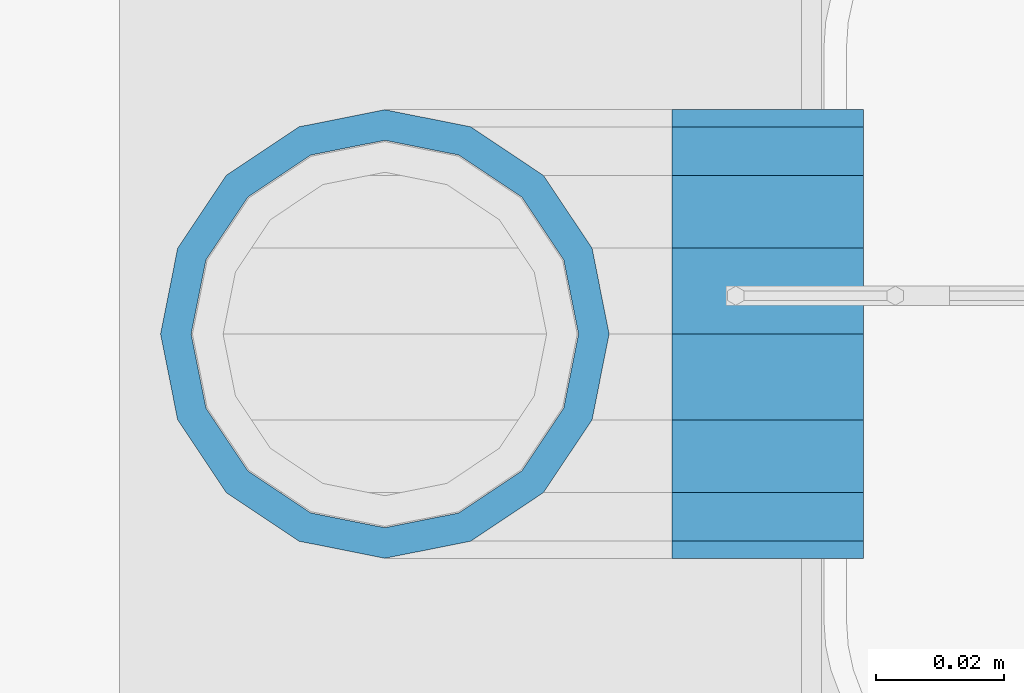
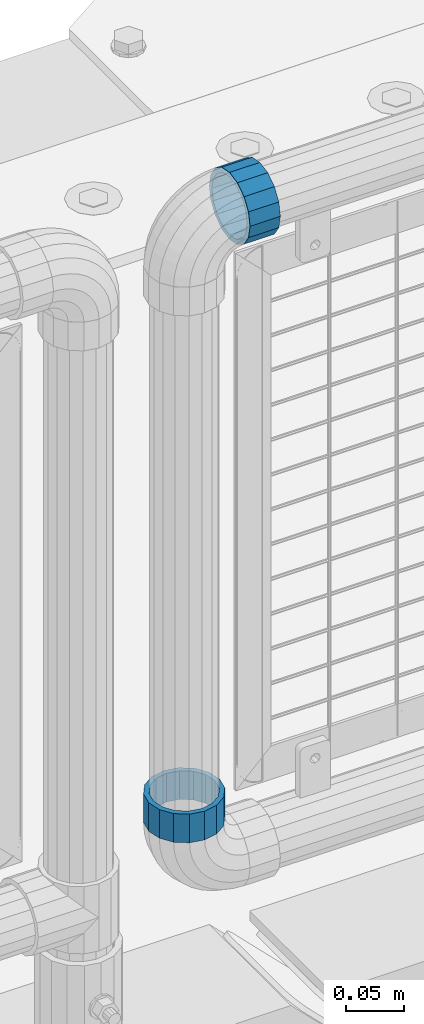
# One storey, part 158 of 240: 2 beams.
"""IFC2X3 building model written with IfcOpenShell, lengths in millimetres."""

from ifc_helpers import new_model, si_unit, frame, origin_with_axes, place, context, subcontext, project, spatial, faceted_brep, material, type_object, element, save


model = new_model("IFC2X3")

# Units and contexts
model_context = context("Model", 3, precision=1e-05, world=origin_with_axes())
body_context = subcontext(model_context, "Body", "Model", "MODEL_VIEW")
ifc_project = project(units=[si_unit("LENGTHUNIT", "METRE", prefix="MILLI"), si_unit("AREAUNIT", "SQUARE_METRE"), si_unit("VOLUMEUNIT", "CUBIC_METRE"), si_unit("MASSUNIT", "GRAM", prefix="KILO"), si_unit("TIMEUNIT", "SECOND"), si_unit("PLANEANGLEUNIT", "RADIAN"), si_unit("SOLIDANGLEUNIT", "STERADIAN"), si_unit("THERMODYNAMICTEMPERATUREUNIT", "DEGREE_CELSIUS"), si_unit("LUMINOUSINTENSITYUNIT", "LUMEN")], contexts=[model_context])

# Site, building, storey
site_placement = place(None, origin_with_axes())
site = spatial("IfcSite", under=ifc_project, at=site_placement, CompositionType="ELEMENT")
building_placement = place(site_placement, origin_with_axes())
building = spatial("IfcBuilding", under=site, at=building_placement, Name="Standard", CompositionType="ELEMENT")
storey_placement = place(building_placement, origin_with_axes())
storey = spatial("IfcBuildingStorey", under=building, at=storey_placement, Name="Undefined", CompositionType="ELEMENT", Elevation=0.0)

# Beams
ifc_material = material(Name="Misc_Undefined")
beam_type = type_object("IfcBeamType", PredefinedType="NOTDEFINED")
beam_1_placement = place(storey_placement, frame((54781.61, 34664.5, 373.170000000002), z_axis=(-1.0, 0.0, 0.0), x_axis=(0.0, 0.0, -1.0)))
element("IfcBeam", 1, at=beam_1_placement, inside=storey, type_object=beam_type, material=ifc_material, context=body_context, shape_type="Brep", body=[
    faceted_brep([(0.0, -30.3499999999985, 0.0), (0.0, -28.0397438117143, 11.6144421722784), (30.0, -28.0397438117143, 11.6144421722805), (30.0, -30.3499999999985, 0.0), (0.0, -21.4606908090136, 21.4606908090136), (30.0, -21.4606908090136, 21.4606908090117), (0.0, -11.6144421722784, 28.0397438117143), (30.0, -11.6144421722784, 28.0397438117176), (0.0, 0.0, 30.3499999999985), (30.0, 0.0, 30.35), (0.0, 11.6144421722784, 28.0397438117143), (30.0, 11.6144421722784, 28.0397438117176), (0.0, 21.4606908090136, 21.4606908090136), (30.0, 21.4606908090136, 21.4606908090117), (0.0, 28.0397438117143, 11.6144421722784), (30.0, 28.0397438117143, 11.6144421722805), (0.0, 30.3499999999985, 0.0), (30.0, 30.3499999999985, 0.0), (0.0, 28.0397438117143, -11.6144421722784), (30.0, 28.0397438117143, -11.6144421722805), (0.0, 21.4606908090136, -21.4606908090136), (30.0, 21.4606908090136, -21.4606908090117), (0.0, 11.6144421722784, -28.0397438117143), (30.0, 11.6144421722784, -28.0397438117176), (0.0, 0.0, -30.3499999999985), (30.0, 0.0, -30.35), (0.0, -11.6144421722784, -28.0397438117143), (30.0, -11.6144421722784, -28.0397438117176), (0.0, -21.4606908090136, -21.4606908090136), (30.0, -21.4606908090136, -21.4606908090117), (0.0, -28.0397438117143, -11.6144421722784), (30.0, -28.0397438117143, -11.6144421722805), (0.0, -35.1500000000015, 0.0), (0.0, -32.4743655677739, -13.4513226476338), (30.0, -32.4743655677739, -13.4513226476329), (30.0, -35.1500000000015, 0.0), (0.0, -24.8548033587067, -24.8548033587067), (30.0, -24.8548033587067, -24.8548033587072), (0.0, -13.4513226476338, -32.4743655677739), (30.0, -13.4513226476338, -32.4743655677718), (0.0, 0.0, -35.1500000000015), (30.0, 0.0, -35.15), (0.0, 13.4513226476338, -32.4743655677739), (30.0, 13.4513226476338, -32.4743655677718), (0.0, 24.8548033587067, -24.8548033587067), (30.0, 24.8548033587067, -24.8548033587072), (0.0, 32.4743655677739, -13.4513226476338), (30.0, 32.4743655677739, -13.4513226476329), (0.0, 35.1500000000015, 0.0), (30.0, 35.1500000000015, 0.0), (0.0, 32.4743655677739, 13.4513226476338), (30.0, 32.4743655677739, 13.4513226476329), (0.0, 24.8548033587067, 24.8548033587067), (30.0, 24.8548033587067, 24.8548033587072), (0.0, 13.4513226476338, 32.4743655677739), (30.0, 13.4513226476338, 32.4743655677718), (0.0, 0.0, 35.1500000000015), (30.0, 0.0, 35.15), (0.0, -13.4513226476338, 32.4743655677739), (30.0, -13.4513226476338, 32.4743655677718), (0.0, -24.8548033587067, 24.8548033587067), (30.0, -24.8548033587067, 24.8548033587072), (0.0, -32.4743655677739, 13.4513226476338), (30.0, -32.4743655677739, 13.4513226476329)], [[[0, 1, 2, 3]], [[1, 4, 5, 2]], [[4, 6, 7, 5]], [[6, 8, 9, 7]], [[8, 10, 11, 9]], [[10, 12, 13, 11]], [[12, 14, 15, 13]], [[14, 16, 17, 15]], [[16, 18, 19, 17]], [[18, 20, 21, 19]], [[20, 22, 23, 21]], [[22, 24, 25, 23]], [[24, 26, 27, 25]], [[26, 28, 29, 27]], [[28, 30, 31, 29]], [[30, 0, 3, 31]], [[32, 33, 34, 35]], [[33, 36, 37, 34]], [[36, 38, 39, 37]], [[38, 40, 41, 39]], [[40, 42, 43, 41]], [[42, 44, 45, 43]], [[44, 46, 47, 45]], [[46, 48, 49, 47]], [[48, 50, 51, 49]], [[50, 52, 53, 51]], [[52, 54, 55, 53]], [[54, 56, 57, 55]], [[56, 58, 59, 57]], [[58, 60, 61, 59]], [[60, 62, 63, 61]], [[62, 32, 35, 63]], [[37, 39, 41, 43, 45, 47, 49, 51, 53, 55, 57, 59, 61, 63, 35, 34], [5, 7, 9, 11, 13, 15, 17, 19, 21, 23, 25, 27, 29, 31, 3, 2]], [[62, 60, 58, 56, 54, 52, 50, 48, 46, 44, 42, 40, 38, 36, 33, 32], [30, 28, 26, 24, 22, 20, 18, 16, 14, 12, 10, 8, 6, 4, 1, 0]]]),
])
beam_2_placement = place(storey_placement, frame((54826.61, 34664.5, 969.849999999999), z_axis=(0.0, 0.0, 1.0), x_axis=(1.0, 0.0, 0.0)))
element("IfcBeam", 2, at=beam_2_placement, inside=storey, type_object=beam_type, material=ifc_material, context=body_context, shape_type="Brep", body=[
    faceted_brep([(0.0, -30.3499999999985, 0.0), (0.0, -28.0397438117143, 11.6144421722784), (30.0, -28.0397438117143, 11.6144421722805), (30.0, -30.3499999999985, 0.0), (0.0, -21.4606908090136, 21.4606908090136), (30.0, -21.4606908090136, 21.4606908090117), (0.0, -11.6144421722784, 28.0397438117143), (30.0, -11.6144421722784, 28.0397438117176), (0.0, 0.0, 30.3499999999985), (30.0, 0.0, 30.35), (0.0, 11.6144421722784, 28.0397438117143), (30.0, 11.6144421722784, 28.0397438117176), (0.0, 21.4606908090136, 21.4606908090136), (30.0, 21.4606908090136, 21.4606908090117), (0.0, 28.0397438117143, 11.6144421722784), (30.0, 28.0397438117143, 11.6144421722805), (0.0, 30.3499999999985, 0.0), (30.0, 30.3499999999985, 0.0), (0.0, 28.0397438117143, -11.6144421722784), (30.0, 28.0397438117143, -11.6144421722805), (0.0, 21.4606908090136, -21.4606908090136), (30.0, 21.4606908090136, -21.4606908090117), (0.0, 11.6144421722784, -28.0397438117143), (30.0, 11.6144421722784, -28.0397438117176), (0.0, 0.0, -30.3499999999985), (30.0, 0.0, -30.35), (0.0, -11.6144421722784, -28.0397438117143), (30.0, -11.6144421722784, -28.0397438117176), (0.0, -21.4606908090136, -21.4606908090136), (30.0, -21.4606908090136, -21.4606908090117), (0.0, -28.0397438117143, -11.6144421722784), (30.0, -28.0397438117143, -11.6144421722805), (0.0, -35.1500000000015, 0.0), (0.0, -32.4743655677739, -13.4513226476338), (30.0, -32.4743655677739, -13.4513226476329), (30.0, -35.1500000000015, 0.0), (0.0, -24.8548033587067, -24.8548033587067), (30.0, -24.8548033587067, -24.8548033587072), (0.0, -13.4513226476338, -32.4743655677739), (30.0, -13.4513226476338, -32.4743655677718), (0.0, 0.0, -35.1500000000015), (30.0, 0.0, -35.15), (0.0, 13.4513226476338, -32.4743655677739), (30.0, 13.4513226476338, -32.4743655677718), (0.0, 24.8548033587067, -24.8548033587067), (30.0, 24.8548033587067, -24.8548033587072), (0.0, 32.4743655677739, -13.4513226476338), (30.0, 32.4743655677739, -13.4513226476329), (0.0, 35.1500000000015, 0.0), (30.0, 35.1500000000015, 0.0), (0.0, 32.4743655677739, 13.4513226476338), (30.0, 32.4743655677739, 13.4513226476329), (0.0, 24.8548033587067, 24.8548033587067), (30.0, 24.8548033587067, 24.8548033587072), (0.0, 13.4513226476338, 32.4743655677739), (30.0, 13.4513226476338, 32.4743655677718), (0.0, 0.0, 35.1500000000015), (30.0, 0.0, 35.15), (0.0, -13.4513226476338, 32.4743655677739), (30.0, -13.4513226476338, 32.4743655677718), (0.0, -24.8548033587067, 24.8548033587067), (30.0, -24.8548033587067, 24.8548033587072), (0.0, -32.4743655677739, 13.4513226476338), (30.0, -32.4743655677739, 13.4513226476329)], [[[0, 1, 2, 3]], [[1, 4, 5, 2]], [[4, 6, 7, 5]], [[6, 8, 9, 7]], [[8, 10, 11, 9]], [[10, 12, 13, 11]], [[12, 14, 15, 13]], [[14, 16, 17, 15]], [[16, 18, 19, 17]], [[18, 20, 21, 19]], [[20, 22, 23, 21]], [[22, 24, 25, 23]], [[24, 26, 27, 25]], [[26, 28, 29, 27]], [[28, 30, 31, 29]], [[30, 0, 3, 31]], [[32, 33, 34, 35]], [[33, 36, 37, 34]], [[36, 38, 39, 37]], [[38, 40, 41, 39]], [[40, 42, 43, 41]], [[42, 44, 45, 43]], [[44, 46, 47, 45]], [[46, 48, 49, 47]], [[48, 50, 51, 49]], [[50, 52, 53, 51]], [[52, 54, 55, 53]], [[54, 56, 57, 55]], [[56, 58, 59, 57]], [[58, 60, 61, 59]], [[60, 62, 63, 61]], [[62, 32, 35, 63]], [[37, 39, 41, 43, 45, 47, 49, 51, 53, 55, 57, 59, 61, 63, 35, 34], [5, 7, 9, 11, 13, 15, 17, 19, 21, 23, 25, 27, 29, 31, 3, 2]], [[62, 60, 58, 56, 54, 52, 50, 48, 46, 44, 42, 40, 38, 36, 33, 32], [30, 28, 26, 24, 22, 20, 18, 16, 14, 12, 10, 8, 6, 4, 1, 0]]]),
])

save(model, "model.ifc")
